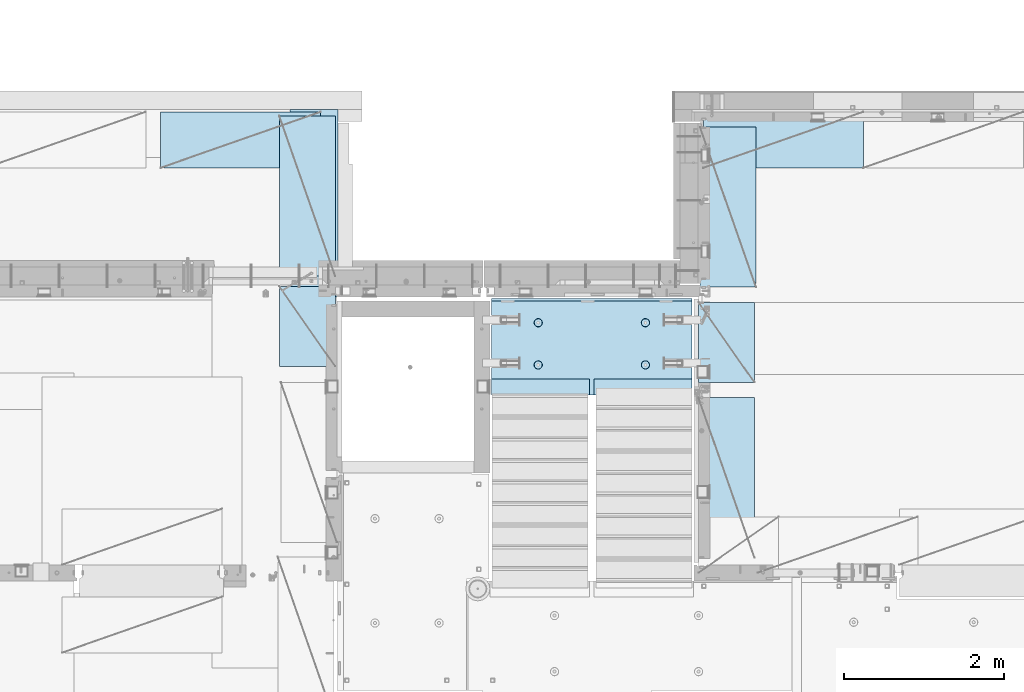
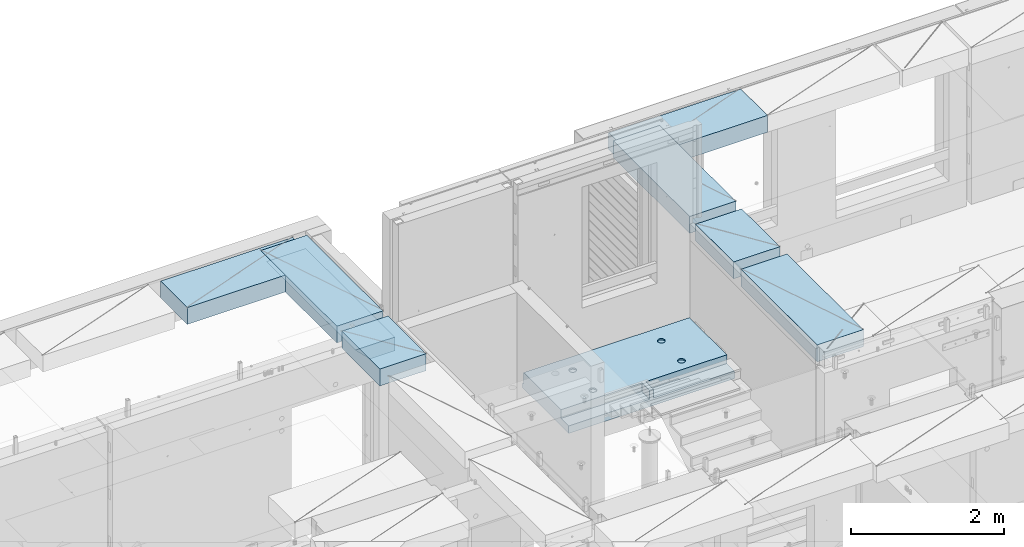
# One storey, part 188 of 325: 7 plates, 2 slabs, 9 elements without a shape of their own.
"""IFC2X3 building model written with IfcOpenShell, lengths in millimetres."""

import ifcopenshell
import ifcopenshell.guid

model = None  # the IFC model being written
_history = None  # IfcOwnerHistory: only IFC2X3 demands one
_inside = {}  # id of a spatial element -> (the spatial element, [elements in it])
_under = {}  # id of a project, library or spatial element -> (it, [spatial elements below it])
_declared = {}  # id of a project -> (the project, [libraries it declares])
_typed = {}  # id of a type object -> (the type object, [elements of that type])
_made_of = {}  # id of a material, layer set ... -> (it, [elements and type objects made of it])


def new_model(schema):
    """Start an empty IFC model of exactly this schema.

    Asked for "IFC4X3", IfcOpenShell would pick the latest addendum, in which some entities
    have other attributes; the version numbers below select the first issue.
    IFC2X3 requires an IfcOwnerHistory on every rooted entity: one is made here for all.
    """
    global model, _history
    if schema == "IFC4X3":
        model = ifcopenshell.file(schema_version=(4, 3, 0, 0))
    else:
        model = ifcopenshell.file(schema=schema)
    _inside.clear()
    _under.clear()
    _declared.clear()
    _typed.clear()
    _made_of.clear()
    _history = None
    if model.schema == "IFC2X3":
        org = make("IfcOrganization", Name="unknown")
        user = make(
            "IfcPersonAndOrganization",
            ThePerson=make("IfcPerson", FamilyName="unknown"),
            TheOrganization=org,
        )
        app = make(
            "IfcApplication",
            ApplicationDeveloper=org,
            Version="unknown",
            ApplicationFullName="unknown",
            ApplicationIdentifier="unknown",
        )
        _history = make(
            "IfcOwnerHistory",
            OwningUser=user,
            OwningApplication=app,
            ChangeAction="ADDED",
            CreationDate=0,
        )
    return model


def make(cls, **values):
    """One entity of the class cls with the attributes given. An attribute that is None is left unset."""
    return model.create_entity(
        cls, **{name: value for name, value in values.items() if value is not None}
    )


def rooted(cls, **values):
    """An entity with a GlobalId (a new one), such as an element, a storey or a relation."""
    return make(cls, GlobalId=ifcopenshell.guid.new(), OwnerHistory=_history, **values)


def si_unit(unit_type, name, prefix=None):
    """IfcSIUnit, for example si_unit("LENGTHUNIT", "METRE", prefix="MILLI")."""
    return make("IfcSIUnit", UnitType=unit_type, Prefix=prefix, Name=name)


def assignment(units):
    """IfcUnitAssignment: the units of a project."""
    return None if units is None else make("IfcUnitAssignment", Units=units)


def point(xyz):
    """IfcCartesianPoint."""
    return None if xyz is None else make("IfcCartesianPoint", Coordinates=xyz)


def direction(xyz):
    """IfcDirection."""
    return None if xyz is None else make("IfcDirection", DirectionRatios=xyz)


def frame(location, z_axis=None, x_axis=None):
    """IfcAxis2Placement3D, a coordinate frame: its origin and axes. An axis left out is left unset."""
    return make(
        "IfcAxis2Placement3D",
        Location=point(location),
        Axis=direction(z_axis),
        RefDirection=direction(x_axis),
    )


def origin_with_axes():
    """The frame at (0, 0, 0) with the z axis (0, 0, 1) and the x axis (1, 0, 0) written out."""
    return frame((0.0, 0.0, 0.0), z_axis=(0.0, 0.0, 1.0), x_axis=(1.0, 0.0, 0.0))


def place(relative_to, where):
    """IfcLocalPlacement: puts the frame where relative to a parent placement (None: the world)."""
    return make(
        "IfcLocalPlacement", PlacementRelTo=relative_to, RelativePlacement=where
    )


def context(
    kind, dimensions, precision=None, world=None, true_north=None, identifier=None
):
    """IfcGeometricRepresentationContext, for example the 3D "Model" context."""
    return make(
        "IfcGeometricRepresentationContext",
        ContextIdentifier=identifier,
        ContextType=kind,
        CoordinateSpaceDimension=dimensions,
        Precision=precision,
        WorldCoordinateSystem=world,
        TrueNorth=true_north,
    )


def subcontext(parent, identifier, kind, view, scale=None):
    """IfcGeometricRepresentationSubContext, for example "Body" below "Model"."""
    return make(
        "IfcGeometricRepresentationSubContext",
        ContextIdentifier=identifier,
        ContextType=kind,
        ParentContext=parent,
        TargetScale=scale,
        TargetView=view,
    )


def project(units=None, contexts=None):
    """IfcProject with its units and contexts."""
    return rooted(
        "IfcProject",
        Name="project",
        RepresentationContexts=contexts,
        UnitsInContext=assignment(units),
    )


def spatial(cls, under=None, at=None, **own):
    """A site, building, storey or space (cls), placed at a placement, below another one or the project."""
    s = rooted(cls, ObjectPlacement=at, **own)
    if under is not None:
        _under.setdefault(under.id(), (under, []))[1].append(s)
    return s


def faces_of(points, faces, orient=None, outer=None):
    """IfcFace entities. A face is a list of loops; a loop is a list of indices into points, from 0.

    orient and outer hold one flag for each loop. By default every Orientation is true, the
    first loop of a face is its IfcFaceOuterBound and the others are IfcFaceBound.
    """
    made = []
    for i, loops in enumerate(faces):
        bounds = []
        for j, loop in enumerate(loops):
            is_outer = j == 0 if outer is None else outer[i][j]
            bounds.append(
                make(
                    "IfcFaceOuterBound" if is_outer else "IfcFaceBound",
                    Bound=make("IfcPolyLoop", Polygon=[points[k] for k in loop]),
                    Orientation=True if orient is None else orient[i][j],
                )
            )
        made.append(make("IfcFace", Bounds=bounds))
    return made


def faceted_brep(points, faces, orient=None, outer=None, voids=None):
    """IfcFacetedBrep: a solid bounded by flat faces; with voids (closed shells), ...WithVoids."""
    shared = [point(p) for p in points]
    hull = make("IfcClosedShell", CfsFaces=faces_of(shared, faces, orient, outer))
    if voids is None:
        return make("IfcFacetedBrep", Outer=hull)
    return make(
        "IfcFacetedBrepWithVoids",
        Outer=hull,
        Voids=[
            make(cls, CfsFaces=faces_of(shared, fs, o, b)) for cls, fs, o, b in voids
        ],
    )


def shape(context_of_items, identifier, shape_type, items):
    """IfcShapeRepresentation: the items that make up one representation, for example the "Body"."""
    return make(
        "IfcShapeRepresentation",
        ContextOfItems=context_of_items,
        RepresentationIdentifier=identifier,
        RepresentationType=shape_type,
        Items=items,
    )


def material(Name=None, Category=None):
    """IfcMaterial."""
    return make("IfcMaterial", Name=Name, Category=Category)


def made_of(thing, what):
    """Note that an element or type object is made of a material, layer set ...; save() writes the relation."""
    if what is not None:
        _made_of.setdefault(what.id(), (what, []))[1].append(thing)
    return thing


def type_object(cls, material=None, **own):
    """A type object (cls), such as IfcWallType, which elements share."""
    return made_of(rooted(cls, **own), material)


def element(
    cls,
    number,
    at=None,
    inside=None,
    cuts=None,
    type_object=None,
    material=None,
    context=None,
    identifier="Body",
    shape_type=None,
    held_by="IfcProductDefinitionShape",
    body=None,
    shapes=None,
    **own,
):
    """One element of the class cls, such as IfcWall. Its Tag is "e" and its number.

    at: its placement. inside: the storey or other place that contains it. cuts: it is an
    opening in that element (IfcRelVoidsElement). A single representation is given by context,
    identifier, shape_type and body (its items); several are given by shapes. held_by: the class
    of the entity that holds the representations. save() writes the other relations.
    """
    e = rooted(cls, Tag="e%d" % number, ObjectPlacement=at, **own)
    if body is not None:
        shapes = [shape(context, identifier, shape_type, body)]
    if shapes is not None:
        e.Representation = make(held_by, Representations=shapes)
    if inside is not None:
        _inside.setdefault(inside.id(), (inside, []))[1].append(e)
    if cuts is not None:
        rooted(
            "IfcRelVoidsElement", RelatingBuildingElement=cuts, RelatedOpeningElement=e
        )
    if type_object is not None:
        _typed.setdefault(type_object.id(), (type_object, []))[1].append(e)
    return made_of(e, material)


def aggregate(whole, parts):
    """IfcRelAggregates: a whole, such as a stair, and the parts it consists of."""
    return rooted("IfcRelAggregates", RelatingObject=whole, RelatedObjects=parts)


def save(model, path):
    """Write the relations noted so far, then the file.

    IfcRelAggregates (storeys below a building ...), IfcRelContainedInSpatialStructure (elements
    in a storey), IfcRelDefinesByType, IfcRelAssociatesMaterial and IfcRelDeclares: one each for
    every whole, place, type object, material and project.
    """
    for whole, parts in _under.values():
        aggregate(whole, parts)
    for where, things in _inside.values():
        rooted(
            "IfcRelContainedInSpatialStructure",
            RelatedElements=things,
            RelatingStructure=where,
        )
    for kind, things in _typed.values():
        rooted("IfcRelDefinesByType", RelatedObjects=things, RelatingType=kind)
    for what, things in _made_of.values():
        rooted("IfcRelAssociatesMaterial", RelatedObjects=things, RelatingMaterial=what)
    for by, libraries in _declared.values():
        rooted("IfcRelDeclares", RelatingContext=by, RelatedDefinitions=libraries)
    model.write(path)


model = new_model("IFC2X3")

# Units and contexts
model_context = context("Model", 3, precision=1e-05, world=origin_with_axes())
body_context = subcontext(model_context, "Body", "Model", "MODEL_VIEW")
ifc_project = project(units=[si_unit("LENGTHUNIT", "METRE", prefix="MILLI"), si_unit("AREAUNIT", "SQUARE_METRE"), si_unit("VOLUMEUNIT", "CUBIC_METRE"), si_unit("MASSUNIT", "GRAM", prefix="KILO"), si_unit("TIMEUNIT", "SECOND"), si_unit("PLANEANGLEUNIT", "RADIAN"), si_unit("SOLIDANGLEUNIT", "STERADIAN"), si_unit("THERMODYNAMICTEMPERATUREUNIT", "DEGREE_CELSIUS"), si_unit("LUMINOUSINTENSITYUNIT", "LUMEN")], contexts=[model_context])

# Site, building, storey
site_placement = place(None, origin_with_axes())
site = spatial("IfcSite", under=ifc_project, at=site_placement, CompositionType="ELEMENT")
building_placement = place(site_placement, origin_with_axes())
building = spatial("IfcBuilding", under=site, at=building_placement, CompositionType="ELEMENT")
storey_placement = place(building_placement, origin_with_axes())
storey = spatial("IfcBuildingStorey", under=building, at=storey_placement, Name="1", CompositionType="ELEMENT", Elevation=0.0)

# Assembly, slab
assembly_1_placement = place(storey_placement, origin_with_axes())
assembly_1 = element("IfcElementAssembly", 1, at=assembly_1_placement, inside=storey, AssemblyPlace="NOTDEFINED", PredefinedType="REINFORCEMENT_UNIT")
ifc_material_1 = material(Name="CONCRETE/C30/37")
slab_type_1 = type_object("IfcSlabType", PredefinedType="NOTDEFINED")
slab_1_placement = place(assembly_1_placement, frame((17760.0001674795, 20429.9999999987, 84350.0), z_axis=(-1.0, 3.00000001838171e-08, 0.0), x_axis=(0.0, 1.0, 0.0)))
slab_1 = element("IfcSlab", 2, at=slab_1_placement, type_object=slab_type_1, material=ifc_material_1, PredefinedType="FLOOR", context=body_context, shape_type="Brep", body=[
    faceted_brep([(2339.998046875, 110.0, 0.0), (0.0, 110.0, 0.0), (2339.998046875, 110.0, 380.0), (0.0, 110.0, 380.0), (2339.998046875, -109.669999999998, 600.0), (1.81898940354586e-12, -110.000000000058, 0.0), (0.0, -110.0, 380.0), (0.0, -110.0, 600.0), (0.0, -109.669999999998, 600.0), (2339.998046875, -110.0, 600.0), (2339.998046875, -110.0, 380.0), (2339.998046875, -110.0, 0.0)], [[[0, 1, 2]], [[3, 2, 1]], [[4, 2, 3]], [[5, 6, 3, 1]], [[6, 7, 8, 3]], [[7, 9, 4, 8]], [[9, 10, 2, 4]], [[10, 11, 0, 2]], [[11, 5, 1, 0]], [[8, 4, 3]], [[11, 10, 9, 7, 6, 5]]]),
])
aggregate(assembly_1, [slab_1])

assembly_2_placement = place(storey_placement, origin_with_axes())
assembly_2 = element("IfcElementAssembly", 3, at=assembly_2_placement, inside=storey, AssemblyPlace="NOTDEFINED", PredefinedType="REINFORCEMENT_UNIT")
ifc_material_2 = material(Name="CONCRETE/C25/30")
slab_type_2 = type_object("IfcSlabType", PredefinedType="NOTDEFINED")
slab_2_placement = place(assembly_2_placement, frame((19680.000385927, 19200.0003517906, 83120.0), z_axis=(0.0, 1.0, 0.0), x_axis=(1.0, 0.0, 0.0)))
slab_2 = element("IfcSlab", 4, at=slab_2_placement, type_object=slab_type_2, material=ifc_material_2, PredefinedType="FLOOR", context=body_context, shape_type="Brep", body=[
    faceted_brep([(1284.99890682963, -130.0, 0.0), (1284.99890682963, 10.0003972196719, 0.0), (1284.99890682963, 10.0003972196719, 200.003967285156), (1284.99890682963, -130.0, 200.003967285156), (2510.00073788432, 10.0003972196719, 200.003967285156), (2509.998046875, 10.0003972196719, 0.0), (2510.00073788432, -130.0, 200.003967285156), (2509.998046875, 60.0, 1210.00146484375), (0.0, 60.0, 1210.00146484375), (0.0, 50.0000001803419, 1180.00146538467), (2509.998046875, 50.0000001803419, 1180.00146538467), (2509.998046875, 130.0, 1210.00146484375), (0.0, 130.0, 1210.00146484375), (2509.998046875, 130.0, 0.0), (0.0, 130.0, -1.81898940354586e-12), (1225.00073788432, 10.0003972196719, 0.0), (1225.00073788432, 10.0003972196719, 200.003967285156), (-0.00109317036549328, 10.0003972196719, 200.003967285156), (0.0, 10.0003972196719, 0.0), (1225.00073788432, -130.0, 200.003967285156), (1225.00073788432, -130.0, 0.0), (0.0, -130.0, 200.003967285156), (0.0, -130.0, 1180.00146417833), (2509.998046875, -130.0, 1180.00146417833), (1940.44809334572, -110.0, 331.258272818675), (1954.3865062416, -110.0, 338.360248914683), (1965.44809334572, -110.0, 349.42183601881), (1972.55006944173, -110.0, 363.360248914683), (1974.99724362697, -110.0, 378.811098633432), (1972.55006944173, -110.0, 394.261948352181), (1965.44809334572, -110.0, 408.200361248055), (1954.3865062416, -110.0, 419.261948352181), (1940.44809334572, -110.0, 426.363924448189), (1924.99724362697, -110.0, 428.811098633432), (1909.54639390823, -110.0, 426.363924448189), (1895.60798101235, -110.0, 419.261948352181), (1884.54639390823, -110.0, 408.200361248055), (1877.44441781222, -110.0, 394.261948352181), (1874.99724362697, -110.0, 378.811098633432), (1877.44441781222, -110.0, 363.360248914683), (1884.54639390823, -110.0, 349.42183601881), (1895.60798101235, -110.0, 338.360248914683), (1909.54639390823, -110.0, 331.258272818675), (1924.99724362697, -110.0, 328.811098633432), (1974.71156152422, -130.0, 394.964259703032), (1977.2699708997, -130.0, 378.811098633432), (1967.28676833294, -130.0, 409.536236821448), (1955.72238181499, -130.0, 421.100623339393), (1941.15040469657, -130.0, 428.52541653068), (1924.99724362697, -130.0, 431.08382590616), (1908.84408255737, -130.0, 428.52541653068), (1894.27210543896, -130.0, 421.100623339393), (1882.70771892101, -130.0, 409.536236821448), (1875.28292572973, -130.0, 394.964259703032), (1872.72451635425, -130.0, 378.811098633432), (1875.28292572973, -130.0, 362.657937563832), (1882.70771892101, -130.0, 348.085960445416), (1894.27210543896, -130.0, 336.521573927472), (1908.84408255737, -130.0, 329.096780736185), (1924.99724362697, -130.0, 326.538371360704), (1941.15040469657, -130.0, 329.096780736185), (1955.72238181499, -130.0, 336.521573927472), (1967.28676833294, -130.0, 348.085960445416), (1974.71156152422, -130.0, 362.657937563832), (1940.44809334572, -110.0, 858.458272818676), (1954.3865062416, -110.0, 865.560248914684), (1965.44809334572, -110.0, 876.62183601881), (1972.55006944173, -110.0, 890.560248914684), (1974.99724362697, -110.0, 906.011098633433), (1972.55006944173, -110.0, 921.461948352182), (1965.44809334572, -110.0, 935.400361248056), (1954.3865062416, -110.0, 946.461948352182), (1940.44809334572, -110.0, 953.56392444819), (1924.99724362697, -110.0, 956.011098633433), (1909.54639390823, -110.0, 953.56392444819), (1895.60798101235, -110.0, 946.461948352182), (1884.54639390823, -110.0, 935.400361248056), (1877.44441781222, -110.0, 921.461948352182), (1874.99724362697, -110.0, 906.011098633433), (1877.44441781222, -110.0, 890.560248914684), (1884.54639390823, -110.0, 876.62183601881), (1895.60798101235, -110.0, 865.560248914684), (1909.54639390823, -110.0, 858.458272818676), (1924.99724362697, -110.0, 856.011098633433), (1974.71156152422, -130.0, 922.164259703033), (1977.2699708997, -130.0, 906.011098633433), (1967.28676833294, -130.0, 936.736236821449), (1955.72238181499, -130.0, 948.300623339394), (1941.15040469657, -130.0, 955.72541653068), (1924.99724362697, -130.0, 958.283825906161), (1908.84408255737, -130.0, 955.72541653068), (1894.27210543896, -130.0, 948.300623339394), (1882.70771892101, -130.0, 936.736236821449), (1875.28292572973, -130.0, 922.164259703033), (1872.72451635425, -130.0, 906.011098633433), (1875.28292572973, -130.0, 889.857937563833), (1882.70771892101, -130.0, 875.285960445417), (1894.27210543896, -130.0, 863.721573927472), (1908.84408255737, -130.0, 856.296780736186), (1924.99724362697, -130.0, 853.738371360705), (1941.15040469657, -130.0, 856.296780736186), (1955.72238181499, -130.0, 863.721573927472), (1967.28676833294, -130.0, 875.285960445417), (1974.71156152422, -130.0, 889.857937563833), (569.611134800252, -110.0, 426.363924448189), (555.672721904379, -110.0, 419.261948352181), (544.611134800252, -110.0, 408.200361248055), (537.509158704244, -110.0, 394.261948352181), (535.061984519001, -110.0, 378.811098633432), (537.509158704244, -110.0, 363.360248914683), (544.611134800252, -110.0, 349.42183601881), (555.672721904379, -110.0, 338.360248914683), (569.611134800252, -110.0, 331.258272818675), (585.061984519001, -110.0, 328.811098633432), (600.51283423775, -110.0, 331.258272818675), (614.451247133624, -110.0, 338.360248914683), (625.51283423775, -110.0, 349.42183601881), (632.614810333758, -110.0, 363.360248914683), (635.061984519001, -110.0, 378.811098633432), (632.614810333758, -110.0, 394.261948352181), (625.51283423775, -110.0, 408.200361248055), (614.451247133624, -110.0, 419.261948352181), (600.51283423775, -110.0, 426.363924448189), (585.061984519001, -110.0, 428.811098633432), (634.776302416249, -130.0, 394.964259703032), (637.334711791729, -130.0, 378.811098633432), (627.351509224962, -130.0, 409.536236821448), (615.787122707017, -130.0, 421.100623339393), (601.215145588601, -130.0, 428.52541653068), (585.061984519001, -130.0, 431.08382590616), (568.908823449401, -130.0, 428.52541653068), (554.336846330985, -130.0, 421.100623339393), (542.772459813041, -130.0, 409.536236821448), (535.347666621754, -130.0, 394.964259703032), (532.789257246273, -130.0, 378.811098633432), (535.347666621754, -130.0, 362.657937563832), (542.772459813041, -130.0, 348.085960445416), (554.336846330985, -130.0, 336.521573927472), (568.908823449401, -130.0, 329.096780736185), (585.061984519001, -130.0, 326.538371360704), (601.215145588601, -130.0, 329.096780736185), (615.787122707017, -130.0, 336.521573927472), (627.351509224962, -130.0, 348.085960445416), (634.776302416249, -130.0, 362.657937563832), (569.611134800252, -110.0, 953.56392444819), (555.672721904379, -110.0, 946.461948352182), (544.611134800252, -110.0, 935.400361248056), (537.509158704244, -110.0, 921.461948352182), (535.061984519001, -110.0, 906.011098633433), (537.509158704244, -110.0, 890.560248914684), (544.611134800252, -110.0, 876.62183601881), (555.672721904379, -110.0, 865.560248914684), (569.611134800252, -110.0, 858.458272818676), (585.061984519001, -110.0, 856.011098633433), (600.51283423775, -110.0, 858.458272818676), (614.451247133624, -110.0, 865.560248914684), (625.51283423775, -110.0, 876.62183601881), (632.614810333758, -110.0, 890.560248914684), (635.061984519001, -110.0, 906.011098633433), (632.614810333758, -110.0, 921.461948352182), (625.51283423775, -110.0, 935.400361248056), (614.451247133624, -110.0, 946.461948352182), (600.51283423775, -110.0, 953.56392444819), (585.061984519001, -110.0, 956.011098633433), (634.776302416249, -130.0, 922.164259703033), (637.334711791729, -130.0, 906.011098633433), (627.351509224962, -130.0, 936.736236821449), (615.787122707017, -130.0, 948.300623339394), (601.215145588601, -130.0, 955.72541653068), (585.061984519001, -130.0, 958.283825906161), (568.908823449401, -130.0, 955.72541653068), (554.336846330985, -130.0, 948.300623339394), (542.772459813041, -130.0, 936.736236821449), (535.347666621754, -130.0, 922.164259703033), (532.789257246273, -130.0, 906.011098633433), (535.347666621754, -130.0, 889.857937563833), (542.772459813041, -130.0, 875.285960445417), (554.336846330985, -130.0, 863.721573927472), (568.908823449401, -130.0, 856.296780736186), (585.061984519001, -130.0, 853.738371360705), (601.215145588601, -130.0, 856.296780736186), (615.787122707017, -130.0, 863.721573927472), (627.351509224962, -130.0, 875.285960445417), (634.776302416249, -130.0, 889.857937563833)], [[[0, 1, 2, 3]], [[4, 2, 1, 5]], [[6, 3, 2, 4]], [[7, 8, 9, 10]], [[11, 12, 8, 7]], [[11, 13, 14, 12]], [[15, 16, 17, 18]], [[19, 16, 15, 20]], [[21, 17, 16, 19]], [[22, 9, 8, 12, 14, 18, 17, 21]], [[23, 10, 9, 22]], [[5, 13, 11, 7, 10, 23, 6, 4]], [[0, 20, 15, 18, 14, 13, 5, 1]], [[24, 25, 26, 27, 28, 29, 30, 31, 32, 33, 34, 35, 36, 37, 38, 39, 40, 41, 42, 43]], [[44, 29, 28, 45]], [[46, 30, 29, 44]], [[47, 31, 30, 46]], [[48, 32, 31, 47]], [[49, 33, 32, 48]], [[50, 34, 33, 49]], [[51, 35, 34, 50]], [[52, 36, 35, 51]], [[53, 37, 36, 52]], [[54, 38, 37, 53]], [[55, 39, 38, 54]], [[56, 40, 39, 55]], [[57, 41, 40, 56]], [[58, 42, 41, 57]], [[59, 43, 42, 58]], [[60, 24, 43, 59]], [[61, 25, 24, 60]], [[62, 26, 25, 61]], [[63, 27, 26, 62]], [[45, 28, 27, 63]], [[64, 65, 66, 67, 68, 69, 70, 71, 72, 73, 74, 75, 76, 77, 78, 79, 80, 81, 82, 83]], [[84, 69, 68, 85]], [[86, 70, 69, 84]], [[87, 71, 70, 86]], [[88, 72, 71, 87]], [[89, 73, 72, 88]], [[90, 74, 73, 89]], [[91, 75, 74, 90]], [[92, 76, 75, 91]], [[93, 77, 76, 92]], [[94, 78, 77, 93]], [[95, 79, 78, 94]], [[96, 80, 79, 95]], [[97, 81, 80, 96]], [[98, 82, 81, 97]], [[99, 83, 82, 98]], [[100, 64, 83, 99]], [[101, 65, 64, 100]], [[102, 66, 65, 101]], [[103, 67, 66, 102]], [[85, 68, 67, 103]], [[104, 105, 106, 107, 108, 109, 110, 111, 112, 113, 114, 115, 116, 117, 118, 119, 120, 121, 122, 123]], [[124, 119, 118, 125]], [[126, 120, 119, 124]], [[127, 121, 120, 126]], [[128, 122, 121, 127]], [[129, 123, 122, 128]], [[130, 104, 123, 129]], [[131, 105, 104, 130]], [[132, 106, 105, 131]], [[133, 107, 106, 132]], [[134, 108, 107, 133]], [[135, 109, 108, 134]], [[136, 110, 109, 135]], [[137, 111, 110, 136]], [[138, 112, 111, 137]], [[139, 113, 112, 138]], [[140, 114, 113, 139]], [[141, 115, 114, 140]], [[142, 116, 115, 141]], [[143, 117, 116, 142]], [[125, 118, 117, 143]], [[144, 145, 146, 147, 148, 149, 150, 151, 152, 153, 154, 155, 156, 157, 158, 159, 160, 161, 162, 163]], [[164, 159, 158, 165]], [[166, 160, 159, 164]], [[167, 161, 160, 166]], [[168, 162, 161, 167]], [[169, 163, 162, 168]], [[170, 144, 163, 169]], [[171, 145, 144, 170]], [[172, 146, 145, 171]], [[173, 147, 146, 172]], [[174, 148, 147, 173]], [[175, 149, 148, 174]], [[176, 150, 149, 175]], [[177, 151, 150, 176]], [[178, 152, 151, 177]], [[179, 153, 152, 178]], [[180, 154, 153, 179]], [[181, 155, 154, 180]], [[182, 156, 155, 181]], [[183, 157, 156, 182]], [[165, 158, 157, 183]], [[23, 22, 21, 19, 20, 0, 3, 6], [182, 181, 180, 179, 178, 177, 176, 175, 174, 173, 172, 171, 170, 169, 168, 167, 166, 164, 165, 183], [142, 141, 140, 139, 138, 137, 136, 135, 134, 133, 132, 131, 130, 129, 128, 127, 126, 124, 125, 143], [102, 101, 100, 99, 98, 97, 96, 95, 94, 93, 92, 91, 90, 89, 88, 87, 86, 84, 85, 103], [62, 61, 60, 59, 58, 57, 56, 55, 54, 53, 52, 51, 50, 49, 48, 47, 46, 44, 45, 63]]]),
])
aggregate(assembly_2, [slab_2])

# Assembly, plate
assembly_3_placement = place(storey_placement, origin_with_axes())
assembly_3 = element("IfcElementAssembly", 5, at=assembly_3_placement, inside=storey, Name="Steel Assembly", AssemblyPlace="NOTDEFINED", PredefinedType="NOTDEFINED")
ifc_material_3 = material()
plate_type = type_object("IfcPlateType", PredefinedType="NOTDEFINED")
plate_1_placement = place(assembly_3_placement, frame((24330.0, 22740.0001220703, 84595.3), z_axis=(0.0, -1.0, 0.0), x_axis=(-1.0, 3.00000001838171e-08, 0.0)))
plate_1 = element("IfcPlate", 6, at=plate_1_placement, type_object=plate_type, material=ifc_material_3, Name="RE1", context=body_context, shape_type="Brep", body=[
    faceted_brep([(1.81898940354586e-12, -135.0, 1.81898940354586e-12), (0.0, -135.0, 699.999999999996), (0.0, 135.0, 699.999999999996), (1.81898940354586e-12, 135.0, 1.81898940354586e-12), (1999.99951171875, -135.0, 699.999999999993), (1999.99951171875, 135.0, 699.999999999993), (2000.0, -135.0, -3.63797880709171e-12), (2000.0, 135.0, -3.63797880709171e-12)], [[[0, 1, 2, 3]], [[1, 4, 5, 2]], [[4, 6, 7, 5]], [[6, 0, 3, 7]], [[5, 7, 3, 2]], [[6, 4, 1, 0]]]),
])
aggregate(assembly_3, [plate_1])

assembly_4_placement = place(storey_placement, origin_with_axes())
assembly_4 = element("IfcElementAssembly", 7, at=assembly_4_placement, inside=storey, Name="Steel Assembly", AssemblyPlace="NOTDEFINED", PredefinedType="NOTDEFINED")
plate_2_placement = place(assembly_4_placement, frame((17730.0001220703, 20690.0, 84595.3), z_axis=(-1.0, 3.00000001838171e-08, 0.0), x_axis=(0.0, 1.0, 0.0)))
plate_2 = element("IfcPlate", 8, at=plate_2_placement, type_object=plate_type, material=ifc_material_3, Name="RE1", context=body_context, shape_type="Brep", body=[
    faceted_brep([(1.81898940354586e-12, -135.0, 1.81898940354586e-12), (0.0, -135.0, 699.999999999996), (0.0, 135.0, 699.999999999996), (1.81898940354586e-12, 135.0, 1.81898940354586e-12), (1999.99951171875, -135.0, 699.999999999993), (1999.99951171875, 135.0, 699.999999999993), (2000.0, -135.0, -3.63797880709171e-12), (2000.0, 135.0, -3.63797880709171e-12)], [[[0, 1, 2, 3]], [[1, 4, 5, 2]], [[4, 6, 7, 5]], [[6, 0, 3, 7]], [[5, 7, 3, 2]], [[6, 4, 1, 0]]]),
])
aggregate(assembly_4, [plate_2])

assembly_5_placement = place(storey_placement, origin_with_axes())
assembly_5 = element("IfcElementAssembly", 9, at=assembly_5_placement, inside=storey, Name="Steel Assembly", AssemblyPlace="NOTDEFINED", PredefinedType="NOTDEFINED")
plate_3_placement = place(assembly_5_placement, frame((22269.9998779297, 19170.0, 84595.3), z_axis=(1.0, 0.0, 0.0), x_axis=(0.0, -1.0, 0.0)))
plate_3 = element("IfcPlate", 10, at=plate_3_placement, type_object=plate_type, material=ifc_material_3, Name="RE1", context=body_context, shape_type="Brep", body=[
    faceted_brep([(1.81898940354586e-12, -135.0, 1.81898940354586e-12), (0.0, -135.0, 699.999999999996), (0.0, 135.0, 699.999999999996), (1.81898940354586e-12, 135.0, 1.81898940354586e-12), (1999.99951171875, -135.0, 699.999999999993), (1999.99951171875, 135.0, 699.999999999993), (2000.0, -135.0, -3.63797880709171e-12), (2000.0, 135.0, -3.63797880709171e-12)], [[[0, 1, 2, 3]], [[1, 4, 5, 2]], [[4, 6, 7, 5]], [[6, 0, 3, 7]], [[5, 7, 3, 2]], [[6, 4, 1, 0]]]),
])
aggregate(assembly_5, [plate_3])

assembly_6_placement = place(storey_placement, origin_with_axes())
assembly_6 = element("IfcElementAssembly", 11, at=assembly_6_placement, inside=storey, Name="Steel Assembly", AssemblyPlace="NOTDEFINED", PredefinedType="NOTDEFINED")
plate_4_placement = place(assembly_6_placement, frame((22289.9998779297, 22550.0, 84595.3), z_axis=(1.0, 0.0, 0.0), x_axis=(0.0, -1.0, 0.0)))
plate_4 = element("IfcPlate", 12, at=plate_4_placement, type_object=plate_type, material=ifc_material_3, Name="RE1", context=body_context, shape_type="Brep", body=[
    faceted_brep([(1.81898940354586e-12, -135.0, 1.81898940354586e-12), (0.0, -135.0, 699.999999999996), (0.0, 135.0, 699.999999999996), (1.81898940354586e-12, 135.0, 1.81898940354586e-12), (1999.99951171875, -135.0, 699.999999999993), (1999.99951171875, 135.0, 699.999999999993), (2000.0, -135.0, -3.63797880709171e-12), (2000.0, 135.0, -3.63797880709171e-12)], [[[0, 1, 2, 3]], [[1, 4, 5, 2]], [[4, 6, 7, 5]], [[6, 0, 3, 7]], [[5, 7, 3, 2]], [[6, 4, 1, 0]]]),
])
aggregate(assembly_6, [plate_4])

assembly_7_placement = place(storey_placement, origin_with_axes())
assembly_7 = element("IfcElementAssembly", 13, at=assembly_7_placement, inside=storey, Name="Steel Assembly", AssemblyPlace="NOTDEFINED", PredefinedType="NOTDEFINED")
plate_5_placement = place(assembly_7_placement, frame((22269.9999999293, 20360.0, 84595.3), z_axis=(1.0, 0.0, 0.0), x_axis=(0.0, -1.0, 0.0)))
plate_5 = element("IfcPlate", 14, at=plate_5_placement, type_object=plate_type, material=ifc_material_3, Name="RE1_1/2", context=body_context, shape_type="Brep", body=[
    faceted_brep([(1.81898940354586e-12, -135.0, 1.81898940354586e-12), (0.0, -135.0, 699.999999999996), (0.0, 135.0, 699.999999999996), (1.81898940354586e-12, 135.0, 1.81898940354586e-12), (999.99951171875, -135.0, 700.0), (999.99951171875, 135.0, 700.0), (1000.0, -135.0, 0.0), (1000.0, 135.0, 0.0)], [[[0, 1, 2, 3]], [[1, 4, 5, 2]], [[4, 6, 7, 5]], [[6, 0, 3, 7]], [[5, 7, 3, 2]], [[6, 4, 1, 0]]]),
])
aggregate(assembly_7, [plate_5])

assembly_8_placement = place(storey_placement, origin_with_axes())
assembly_8 = element("IfcElementAssembly", 15, at=assembly_8_placement, inside=storey, Name="Steel Assembly", AssemblyPlace="NOTDEFINED", PredefinedType="NOTDEFINED")
plate_6_placement = place(assembly_8_placement, frame((17730.0000000707, 19560.0, 84595.3), z_axis=(-1.0, 3.00000001838171e-08, 0.0), x_axis=(0.0, 1.0, 0.0)))
plate_6 = element("IfcPlate", 16, at=plate_6_placement, type_object=plate_type, material=ifc_material_3, Name="RE1_1/2", context=body_context, shape_type="Brep", body=[
    faceted_brep([(1.81898940354586e-12, -135.0, 1.81898940354586e-12), (0.0, -135.0, 699.999999999996), (0.0, 135.0, 699.999999999996), (1.81898940354586e-12, 135.0, 1.81898940354586e-12), (999.99951171875, -135.0, 700.0), (999.99951171875, 135.0, 700.0), (1000.0, -135.0, 0.0), (1000.0, 135.0, 0.0)], [[[0, 1, 2, 3]], [[1, 4, 5, 2]], [[4, 6, 7, 5]], [[6, 0, 3, 7]], [[5, 7, 3, 2]], [[6, 4, 1, 0]]]),
])
aggregate(assembly_8, [plate_6])

assembly_9_placement = place(storey_placement, origin_with_axes())
assembly_9 = element("IfcElementAssembly", 17, at=assembly_9_placement, inside=storey, Name="Steel Assembly", AssemblyPlace="NOTDEFINED", PredefinedType="NOTDEFINED")
plate_7_placement = place(assembly_9_placement, frame((17545.0, 22740.0001220703, 84595.3), z_axis=(0.0, -1.0, 0.0), x_axis=(-1.0, 3.00000001838171e-08, 0.0)))
plate_7 = element("IfcPlate", 18, at=plate_7_placement, type_object=plate_type, material=ifc_material_3, Name="RE1", context=body_context, shape_type="Brep", body=[
    faceted_brep([(1.81898940354586e-12, -135.0, 1.81898940354586e-12), (0.0, -135.0, 699.999999999996), (0.0, 135.0, 699.999999999996), (1.81898940354586e-12, 135.0, 1.81898940354586e-12), (1999.99951171875, -135.0, 699.999999999993), (1999.99951171875, 135.0, 699.999999999993), (2000.0, -135.0, -3.63797880709171e-12), (2000.0, 135.0, -3.63797880709171e-12)], [[[0, 1, 2, 3]], [[1, 4, 5, 2]], [[4, 6, 7, 5]], [[6, 0, 3, 7]], [[5, 7, 3, 2]], [[6, 4, 1, 0]]]),
])
aggregate(assembly_9, [plate_7])

save(model, "model.ifc")
